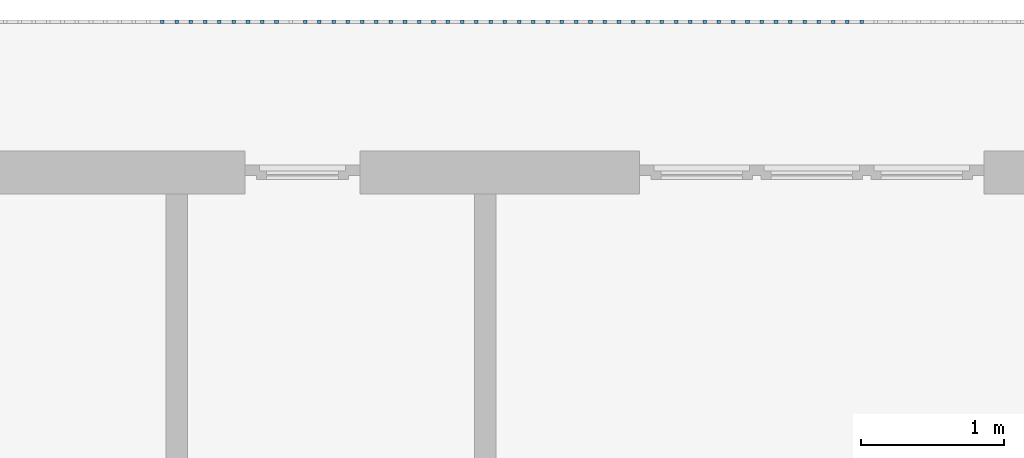
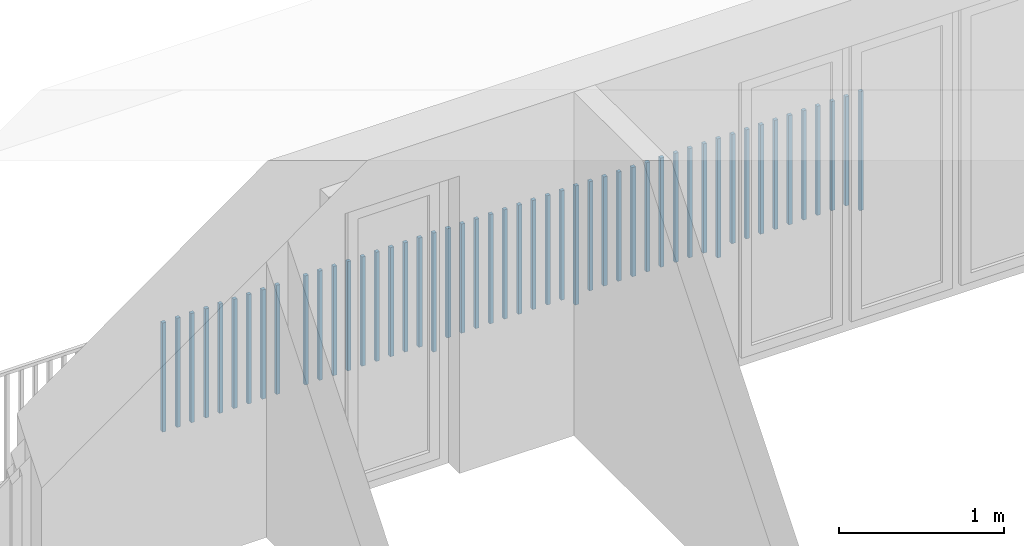
# One storey, part 49 of 54: 49 building element parts, 1 element without a shape of its own.
"""IFC4 building model written with IfcOpenShell, lengths in metres."""

from ifc_helpers import new_model, entity, si_unit, converted_unit, derived_unit, direction, frame, origin_with_axes, place, context, subcontext, project, spatial, polygons, material, type_object, element, aggregate, save


model = new_model("IFC4")

# Units and contexts
model_context = context("Model", 3, precision=1e-05, world=origin_with_axes(), true_north=direction((0.0, 1.0)))
body_context = subcontext(model_context, "Body", "Model", "MODEL_VIEW")
ifc_project = project(units=[si_unit("LENGTHUNIT", "METRE"), si_unit("AREAUNIT", "SQUARE_METRE"), si_unit("VOLUMEUNIT", "CUBIC_METRE"), converted_unit("PLANEANGLEUNIT", "DEGREE", entity("IfcPlaneAngleMeasure", 0.0174532925199), si_unit("PLANEANGLEUNIT", "RADIAN"), dimensions=[0, 0, 0, 0, 0, 0, 0]), converted_unit("TIMEUNIT", "Year", entity("IfcTimeMeasure", 31556926.0), si_unit("TIMEUNIT", "SECOND"), dimensions=[0, 0, 1, 0, 0, 0, 0]), si_unit("MASSUNIT", "GRAM", prefix="KILO"), si_unit("THERMODYNAMICTEMPERATUREUNIT", "DEGREE_CELSIUS"), si_unit("LUMINOUSINTENSITYUNIT", "LUMEN"), si_unit("ENERGYUNIT", "JOULE", prefix="MEGA"), derived_unit("THERMALCONDUCTANCEUNIT", [(si_unit("POWERUNIT", "WATT"), 1), (si_unit("LENGTHUNIT", "METRE"), -1), (si_unit("THERMODYNAMICTEMPERATUREUNIT", "KELVIN"), -1)]), derived_unit("SPECIFICHEATCAPACITYUNIT", [(si_unit("ENERGYUNIT", "JOULE"), 1), (si_unit("MASSUNIT", "GRAM", prefix="KILO"), -1), (si_unit("THERMODYNAMICTEMPERATUREUNIT", "KELVIN"), -1)]), derived_unit("MASSDENSITYUNIT", [(si_unit("MASSUNIT", "GRAM", prefix="KILO"), 1), (si_unit("VOLUMEUNIT", "CUBIC_METRE"), -1)])], contexts=[model_context])

# Site, building, storey, space
site_placement = place(None, origin_with_axes())
site = spatial("IfcSite", under=ifc_project, at=site_placement, CompositionType="ELEMENT")
building_placement = place(site_placement, origin_with_axes())
building = spatial("IfcBuilding", under=site, at=building_placement, CompositionType="ELEMENT")
storey_placement = place(building_placement, frame((0.0, 0.0, 6.29), z_axis=(0.0, 0.0, 1.0), x_axis=(1.0, 0.0, 0.0)))
storey = spatial("IfcBuildingStorey", under=building, at=storey_placement, Name="2. Geschoss", CompositionType="ELEMENT", Elevation=6.29)
space_placement = place(storey_placement, frame((10.2378006196, 9.82118769833, 0.0), z_axis=(0.0, 0.0, 1.0), x_axis=(-1.0, 0.0, 0.0)))
space = spatial("IfcSpace", under=storey, at=space_placement, CompositionType="ELEMENT", PredefinedType="EXTERNAL")

# Railing, building element parts
railing_type = type_object("IfcRailingType", PredefinedType="NOTDEFINED")
railing_placement = place(space_placement, frame((0.0, -7.06315681498e-08, 0.0), z_axis=(0.0, 0.0, 1.0), x_axis=(-1.0, 0.0, 0.0)))
railing = element("IfcRailing", 1, at=railing_placement, inside=space, type_object=railing_type, PredefinedType="NOTDEFINED")
ifc_material = material()
building_element_part_1_placement = place(railing_placement, origin_with_axes())
building_element_part_1 = element("IfcBuildingElementPart", 2, at=building_element_part_1_placement, material=ifc_material, PredefinedType="NOTDEFINED", context=body_context, shape_type="Tessellation", body=[
    polygons([(-12.944673913, 0.0125, 0.0), (-12.944673913, -0.0125, 0.0), (-12.944673913, -0.0125, 0.88), (-12.944673913, 0.0125, 0.88), (-12.919673913, 0.0125, 0.0), (-12.919673913, -0.0125, 0.0), (-12.919673913, -0.0125, 0.88), (-12.919673913, 0.0125, 0.88)], [[[1, 2, 3, 4]], [[1, 5, 6, 2]], [[2, 6, 7, 3]], [[4, 3, 7, 8]], [[5, 1, 4, 8]], [[6, 5, 8, 7]]], closed=True),
])
building_element_part_2_placement = place(railing_placement, origin_with_axes())
building_element_part_2 = element("IfcBuildingElementPart", 3, at=building_element_part_2_placement, material=ifc_material, PredefinedType="NOTDEFINED", context=body_context, shape_type="Tessellation", body=[
    polygons([(-13.0441521739, 0.0125, 0.07), (-13.0441521739, -0.0125, 0.07), (-13.0441521739, -0.0125, 0.8775), (-13.0441521739, 0.0125, 0.8775), (-13.0191521739, 0.0125, 0.07), (-13.0191521739, -0.0125, 0.07), (-13.0191521739, -0.0125, 0.8775), (-13.0191521739, 0.0125, 0.8775)], [[[1, 2, 3, 4]], [[1, 5, 6, 2]], [[2, 6, 7, 3]], [[4, 3, 7, 8]], [[5, 1, 4, 8]], [[6, 5, 8, 7]]], closed=True),
])
building_element_part_3_placement = place(railing_placement, origin_with_axes())
building_element_part_3 = element("IfcBuildingElementPart", 4, at=building_element_part_3_placement, material=ifc_material, PredefinedType="NOTDEFINED", context=body_context, shape_type="Tessellation", body=[
    polygons([(-13.1436304348, 0.0125, 0.07), (-13.1436304348, -0.0125, 0.07), (-13.1436304348, -0.0125, 0.8775), (-13.1436304348, 0.0125, 0.8775), (-13.1186304348, 0.0125, 0.07), (-13.1186304348, -0.0125, 0.07), (-13.1186304348, -0.0125, 0.8775), (-13.1186304348, 0.0125, 0.8775)], [[[1, 2, 3, 4]], [[1, 5, 6, 2]], [[2, 6, 7, 3]], [[4, 3, 7, 8]], [[5, 1, 4, 8]], [[6, 5, 8, 7]]], closed=True),
])
building_element_part_4_placement = place(railing_placement, origin_with_axes())
building_element_part_4 = element("IfcBuildingElementPart", 5, at=building_element_part_4_placement, material=ifc_material, PredefinedType="NOTDEFINED", context=body_context, shape_type="Tessellation", body=[
    polygons([(-13.2431086957, 0.0125, 0.07), (-13.2431086957, -0.0125, 0.07), (-13.2431086957, -0.0125, 0.8775), (-13.2431086957, 0.0125, 0.8775), (-13.2181086957, 0.0125, 0.07), (-13.2181086957, -0.0125, 0.07), (-13.2181086957, -0.0125, 0.8775), (-13.2181086957, 0.0125, 0.8775)], [[[1, 2, 3, 4]], [[1, 5, 6, 2]], [[2, 6, 7, 3]], [[4, 3, 7, 8]], [[5, 1, 4, 8]], [[6, 5, 8, 7]]], closed=True),
])
building_element_part_5_placement = place(railing_placement, origin_with_axes())
building_element_part_5 = element("IfcBuildingElementPart", 6, at=building_element_part_5_placement, material=ifc_material, PredefinedType="NOTDEFINED", context=body_context, shape_type="Tessellation", body=[
    polygons([(-13.3425869565, 0.0125, 0.07), (-13.3425869565, -0.0125, 0.07), (-13.3425869565, -0.0125, 0.8775), (-13.3425869565, 0.0125, 0.8775), (-13.3175869565, 0.0125, 0.07), (-13.3175869565, -0.0125, 0.07), (-13.3175869565, -0.0125, 0.8775), (-13.3175869565, 0.0125, 0.8775)], [[[1, 2, 3, 4]], [[1, 5, 6, 2]], [[2, 6, 7, 3]], [[4, 3, 7, 8]], [[5, 1, 4, 8]], [[6, 5, 8, 7]]], closed=True),
])
building_element_part_6_placement = place(railing_placement, origin_with_axes())
building_element_part_6 = element("IfcBuildingElementPart", 7, at=building_element_part_6_placement, material=ifc_material, PredefinedType="NOTDEFINED", context=body_context, shape_type="Tessellation", body=[
    polygons([(-13.4420652174, 0.0125, 0.07), (-13.4420652174, -0.0125, 0.07), (-13.4420652174, -0.0125, 0.8775), (-13.4420652174, 0.0125, 0.8775), (-13.4170652174, 0.0125, 0.07), (-13.4170652174, -0.0125, 0.07), (-13.4170652174, -0.0125, 0.8775), (-13.4170652174, 0.0125, 0.8775)], [[[1, 2, 3, 4]], [[1, 5, 6, 2]], [[2, 6, 7, 3]], [[4, 3, 7, 8]], [[5, 1, 4, 8]], [[6, 5, 8, 7]]], closed=True),
])
building_element_part_7_placement = place(railing_placement, origin_with_axes())
building_element_part_7 = element("IfcBuildingElementPart", 8, at=building_element_part_7_placement, material=ifc_material, PredefinedType="NOTDEFINED", context=body_context, shape_type="Tessellation", body=[
    polygons([(-13.5415434783, 0.0125, 0.07), (-13.5415434783, -0.0125, 0.07), (-13.5415434783, -0.0125, 0.8775), (-13.5415434783, 0.0125, 0.8775), (-13.5165434783, 0.0125, 0.07), (-13.5165434783, -0.0125, 0.07), (-13.5165434783, -0.0125, 0.8775), (-13.5165434783, 0.0125, 0.8775)], [[[1, 2, 3, 4]], [[1, 5, 6, 2]], [[2, 6, 7, 3]], [[4, 3, 7, 8]], [[5, 1, 4, 8]], [[6, 5, 8, 7]]], closed=True),
])
building_element_part_8_placement = place(railing_placement, origin_with_axes())
building_element_part_8 = element("IfcBuildingElementPart", 9, at=building_element_part_8_placement, material=ifc_material, PredefinedType="NOTDEFINED", context=body_context, shape_type="Tessellation", body=[
    polygons([(-13.6410217391, 0.0125, 0.07), (-13.6410217391, -0.0125, 0.07), (-13.6410217391, -0.0125, 0.8775), (-13.6410217391, 0.0125, 0.8775), (-13.6160217391, 0.0125, 0.07), (-13.6160217391, -0.0125, 0.07), (-13.6160217391, -0.0125, 0.8775), (-13.6160217391, 0.0125, 0.8775)], [[[1, 2, 3, 4]], [[1, 5, 6, 2]], [[2, 6, 7, 3]], [[4, 3, 7, 8]], [[5, 1, 4, 8]], [[6, 5, 8, 7]]], closed=True),
])
building_element_part_9_placement = place(railing_placement, origin_with_axes())
building_element_part_9 = element("IfcBuildingElementPart", 10, at=building_element_part_9_placement, material=ifc_material, PredefinedType="NOTDEFINED", context=body_context, shape_type="Tessellation", body=[
    polygons([(-13.7405, 0.0125, 0.07), (-13.7405, -0.0125, 0.07), (-13.7405, -0.0125, 0.8775), (-13.7405, 0.0125, 0.8775), (-13.7155, 0.0125, 0.07), (-13.7155, -0.0125, 0.07), (-13.7155, -0.0125, 0.8775), (-13.7155, 0.0125, 0.8775)], [[[1, 2, 3, 4]], [[1, 5, 6, 2]], [[2, 6, 7, 3]], [[4, 3, 7, 8]], [[5, 1, 4, 8]], [[6, 5, 8, 7]]], closed=True),
])
building_element_part_10_placement = place(railing_placement, origin_with_axes())
building_element_part_10 = element("IfcBuildingElementPart", 11, at=building_element_part_10_placement, material=ifc_material, PredefinedType="NOTDEFINED", context=body_context, shape_type="Tessellation", body=[
    polygons([(-13.8399782609, 0.0125, 0.07), (-13.8399782609, -0.0125, 0.07), (-13.8399782609, -0.0125, 0.8775), (-13.8399782609, 0.0125, 0.8775), (-13.8149782609, 0.0125, 0.07), (-13.8149782609, -0.0125, 0.07), (-13.8149782609, -0.0125, 0.8775), (-13.8149782609, 0.0125, 0.8775)], [[[1, 2, 3, 4]], [[1, 5, 6, 2]], [[2, 6, 7, 3]], [[4, 3, 7, 8]], [[5, 1, 4, 8]], [[6, 5, 8, 7]]], closed=True),
])
building_element_part_11_placement = place(railing_placement, origin_with_axes())
building_element_part_11 = element("IfcBuildingElementPart", 12, at=building_element_part_11_placement, material=ifc_material, PredefinedType="NOTDEFINED", context=body_context, shape_type="Tessellation", body=[
    polygons([(-13.9394565217, 0.0125, 0.0), (-13.9394565217, -0.0125, 0.0), (-13.9394565217, -0.0125, 0.88), (-13.9394565217, 0.0125, 0.88), (-13.9144565217, 0.0125, 0.0), (-13.9144565217, -0.0125, 0.0), (-13.9144565217, -0.0125, 0.88), (-13.9144565217, 0.0125, 0.88)], [[[1, 2, 3, 4]], [[1, 5, 6, 2]], [[2, 6, 7, 3]], [[4, 3, 7, 8]], [[5, 1, 4, 8]], [[6, 5, 8, 7]]], closed=True),
])
building_element_part_12_placement = place(railing_placement, origin_with_axes())
building_element_part_12 = element("IfcBuildingElementPart", 13, at=building_element_part_12_placement, material=ifc_material, PredefinedType="NOTDEFINED", context=body_context, shape_type="Tessellation", body=[
    polygons([(-14.0389347826, 0.0125, 0.07), (-14.0389347826, -0.0125, 0.07), (-14.0389347826, -0.0125, 0.8775), (-14.0389347826, 0.0125, 0.8775), (-14.0139347826, 0.0125, 0.07), (-14.0139347826, -0.0125, 0.07), (-14.0139347826, -0.0125, 0.8775), (-14.0139347826, 0.0125, 0.8775)], [[[1, 2, 3, 4]], [[1, 5, 6, 2]], [[2, 6, 7, 3]], [[4, 3, 7, 8]], [[5, 1, 4, 8]], [[6, 5, 8, 7]]], closed=True),
])
building_element_part_13_placement = place(railing_placement, origin_with_axes())
building_element_part_13 = element("IfcBuildingElementPart", 14, at=building_element_part_13_placement, material=ifc_material, PredefinedType="NOTDEFINED", context=body_context, shape_type="Tessellation", body=[
    polygons([(-14.1384130435, 0.0125, 0.07), (-14.1384130435, -0.0125, 0.07), (-14.1384130435, -0.0125, 0.8775), (-14.1384130435, 0.0125, 0.8775), (-14.1134130435, 0.0125, 0.07), (-14.1134130435, -0.0125, 0.07), (-14.1134130435, -0.0125, 0.8775), (-14.1134130435, 0.0125, 0.8775)], [[[1, 2, 3, 4]], [[1, 5, 6, 2]], [[2, 6, 7, 3]], [[4, 3, 7, 8]], [[5, 1, 4, 8]], [[6, 5, 8, 7]]], closed=True),
])
building_element_part_14_placement = place(railing_placement, origin_with_axes())
building_element_part_14 = element("IfcBuildingElementPart", 15, at=building_element_part_14_placement, material=ifc_material, PredefinedType="NOTDEFINED", context=body_context, shape_type="Tessellation", body=[
    polygons([(-14.2378913043, 0.0125, 0.07), (-14.2378913043, -0.0125, 0.07), (-14.2378913043, -0.0125, 0.8775), (-14.2378913043, 0.0125, 0.8775), (-14.2128913043, 0.0125, 0.07), (-14.2128913043, -0.0125, 0.07), (-14.2128913043, -0.0125, 0.8775), (-14.2128913043, 0.0125, 0.8775)], [[[1, 2, 3, 4]], [[1, 5, 6, 2]], [[2, 6, 7, 3]], [[4, 3, 7, 8]], [[5, 1, 4, 8]], [[6, 5, 8, 7]]], closed=True),
])
building_element_part_15_placement = place(railing_placement, origin_with_axes())
building_element_part_15 = element("IfcBuildingElementPart", 16, at=building_element_part_15_placement, material=ifc_material, PredefinedType="NOTDEFINED", context=body_context, shape_type="Tessellation", body=[
    polygons([(-14.3373695652, 0.0125, 0.07), (-14.3373695652, -0.0125, 0.07), (-14.3373695652, -0.0125, 0.8775), (-14.3373695652, 0.0125, 0.8775), (-14.3123695652, 0.0125, 0.07), (-14.3123695652, -0.0125, 0.07), (-14.3123695652, -0.0125, 0.8775), (-14.3123695652, 0.0125, 0.8775)], [[[1, 2, 3, 4]], [[1, 5, 6, 2]], [[2, 6, 7, 3]], [[4, 3, 7, 8]], [[5, 1, 4, 8]], [[6, 5, 8, 7]]], closed=True),
])
building_element_part_16_placement = place(railing_placement, origin_with_axes())
building_element_part_16 = element("IfcBuildingElementPart", 17, at=building_element_part_16_placement, material=ifc_material, PredefinedType="NOTDEFINED", context=body_context, shape_type="Tessellation", body=[
    polygons([(-14.4368478261, 0.0125, 0.07), (-14.4368478261, -0.0125, 0.07), (-14.4368478261, -0.0125, 0.8775), (-14.4368478261, 0.0125, 0.8775), (-14.4118478261, 0.0125, 0.07), (-14.4118478261, -0.0125, 0.07), (-14.4118478261, -0.0125, 0.8775), (-14.4118478261, 0.0125, 0.8775)], [[[1, 2, 3, 4]], [[1, 5, 6, 2]], [[2, 6, 7, 3]], [[4, 3, 7, 8]], [[5, 1, 4, 8]], [[6, 5, 8, 7]]], closed=True),
])
building_element_part_17_placement = place(railing_placement, origin_with_axes())
building_element_part_17 = element("IfcBuildingElementPart", 18, at=building_element_part_17_placement, material=ifc_material, PredefinedType="NOTDEFINED", context=body_context, shape_type="Tessellation", body=[
    polygons([(-14.536326087, 0.0125, 0.07), (-14.536326087, -0.0125, 0.07), (-14.536326087, -0.0125, 0.8775), (-14.536326087, 0.0125, 0.8775), (-14.511326087, 0.0125, 0.07), (-14.511326087, -0.0125, 0.07), (-14.511326087, -0.0125, 0.8775), (-14.511326087, 0.0125, 0.8775)], [[[1, 2, 3, 4]], [[1, 5, 6, 2]], [[2, 6, 7, 3]], [[4, 3, 7, 8]], [[5, 1, 4, 8]], [[6, 5, 8, 7]]], closed=True),
])
building_element_part_18_placement = place(railing_placement, origin_with_axes())
building_element_part_18 = element("IfcBuildingElementPart", 19, at=building_element_part_18_placement, material=ifc_material, PredefinedType="NOTDEFINED", context=body_context, shape_type="Tessellation", body=[
    polygons([(-14.6358043478, 0.0125, 0.07), (-14.6358043478, -0.0125, 0.07), (-14.6358043478, -0.0125, 0.8775), (-14.6358043478, 0.0125, 0.8775), (-14.6108043478, 0.0125, 0.07), (-14.6108043478, -0.0125, 0.07), (-14.6108043478, -0.0125, 0.8775), (-14.6108043478, 0.0125, 0.8775)], [[[1, 2, 3, 4]], [[1, 5, 6, 2]], [[2, 6, 7, 3]], [[4, 3, 7, 8]], [[5, 1, 4, 8]], [[6, 5, 8, 7]]], closed=True),
])
building_element_part_19_placement = place(railing_placement, origin_with_axes())
building_element_part_19 = element("IfcBuildingElementPart", 20, at=building_element_part_19_placement, material=ifc_material, PredefinedType="NOTDEFINED", context=body_context, shape_type="Tessellation", body=[
    polygons([(-14.7352826087, 0.0125, 0.07), (-14.7352826087, -0.0125, 0.07), (-14.7352826087, -0.0125, 0.8775), (-14.7352826087, 0.0125, 0.8775), (-14.7102826087, 0.0125, 0.07), (-14.7102826087, -0.0125, 0.07), (-14.7102826087, -0.0125, 0.8775), (-14.7102826087, 0.0125, 0.8775)], [[[1, 2, 3, 4]], [[1, 5, 6, 2]], [[2, 6, 7, 3]], [[4, 3, 7, 8]], [[5, 1, 4, 8]], [[6, 5, 8, 7]]], closed=True),
])
building_element_part_20_placement = place(railing_placement, origin_with_axes())
building_element_part_20 = element("IfcBuildingElementPart", 21, at=building_element_part_20_placement, material=ifc_material, PredefinedType="NOTDEFINED", context=body_context, shape_type="Tessellation", body=[
    polygons([(-14.8347608696, 0.0125, 0.07), (-14.8347608696, -0.0125, 0.07), (-14.8347608696, -0.0125, 0.8775), (-14.8347608696, 0.0125, 0.8775), (-14.8097608696, 0.0125, 0.07), (-14.8097608696, -0.0125, 0.07), (-14.8097608696, -0.0125, 0.8775), (-14.8097608696, 0.0125, 0.8775)], [[[1, 2, 3, 4]], [[1, 5, 6, 2]], [[2, 6, 7, 3]], [[4, 3, 7, 8]], [[5, 1, 4, 8]], [[6, 5, 8, 7]]], closed=True),
])
building_element_part_21_placement = place(railing_placement, origin_with_axes())
building_element_part_21 = element("IfcBuildingElementPart", 22, at=building_element_part_21_placement, material=ifc_material, PredefinedType="NOTDEFINED", context=body_context, shape_type="Tessellation", body=[
    polygons([(-14.9342391304, 0.0125, 0.0), (-14.9342391304, -0.0125, 0.0), (-14.9342391304, -0.0125, 0.88), (-14.9342391304, 0.0125, 0.88), (-14.9092391304, 0.0125, 0.0), (-14.9092391304, -0.0125, 0.0), (-14.9092391304, -0.0125, 0.88), (-14.9092391304, 0.0125, 0.88)], [[[1, 2, 3, 4]], [[1, 5, 6, 2]], [[2, 6, 7, 3]], [[4, 3, 7, 8]], [[5, 1, 4, 8]], [[6, 5, 8, 7]]], closed=True),
])
building_element_part_22_placement = place(railing_placement, origin_with_axes())
building_element_part_22 = element("IfcBuildingElementPart", 23, at=building_element_part_22_placement, material=ifc_material, PredefinedType="NOTDEFINED", context=body_context, shape_type="Tessellation", body=[
    polygons([(-15.0337173913, 0.0125, 0.07), (-15.0337173913, -0.0125, 0.07), (-15.0337173913, -0.0125, 0.8775), (-15.0337173913, 0.0125, 0.8775), (-15.0087173913, 0.0125, 0.07), (-15.0087173913, -0.0125, 0.07), (-15.0087173913, -0.0125, 0.8775), (-15.0087173913, 0.0125, 0.8775)], [[[1, 2, 3, 4]], [[1, 5, 6, 2]], [[2, 6, 7, 3]], [[4, 3, 7, 8]], [[5, 1, 4, 8]], [[6, 5, 8, 7]]], closed=True),
])
building_element_part_23_placement = place(railing_placement, origin_with_axes())
building_element_part_23 = element("IfcBuildingElementPart", 24, at=building_element_part_23_placement, material=ifc_material, PredefinedType="NOTDEFINED", context=body_context, shape_type="Tessellation", body=[
    polygons([(-15.1331956522, 0.0125, 0.07), (-15.1331956522, -0.0125, 0.07), (-15.1331956522, -0.0125, 0.8775), (-15.1331956522, 0.0125, 0.8775), (-15.1081956522, 0.0125, 0.07), (-15.1081956522, -0.0125, 0.07), (-15.1081956522, -0.0125, 0.8775), (-15.1081956522, 0.0125, 0.8775)], [[[1, 2, 3, 4]], [[1, 5, 6, 2]], [[2, 6, 7, 3]], [[4, 3, 7, 8]], [[5, 1, 4, 8]], [[6, 5, 8, 7]]], closed=True),
])
building_element_part_24_placement = place(railing_placement, origin_with_axes())
building_element_part_24 = element("IfcBuildingElementPart", 25, at=building_element_part_24_placement, material=ifc_material, PredefinedType="NOTDEFINED", context=body_context, shape_type="Tessellation", body=[
    polygons([(-15.232673913, 0.0125, 0.07), (-15.232673913, -0.0125, 0.07), (-15.232673913, -0.0125, 0.8775), (-15.232673913, 0.0125, 0.8775), (-15.207673913, 0.0125, 0.07), (-15.207673913, -0.0125, 0.07), (-15.207673913, -0.0125, 0.8775), (-15.207673913, 0.0125, 0.8775)], [[[1, 2, 3, 4]], [[1, 5, 6, 2]], [[2, 6, 7, 3]], [[4, 3, 7, 8]], [[5, 1, 4, 8]], [[6, 5, 8, 7]]], closed=True),
])
building_element_part_25_placement = place(railing_placement, origin_with_axes())
building_element_part_25 = element("IfcBuildingElementPart", 26, at=building_element_part_25_placement, material=ifc_material, PredefinedType="NOTDEFINED", context=body_context, shape_type="Tessellation", body=[
    polygons([(-15.3321521739, 0.0125, 0.07), (-15.3321521739, -0.0125, 0.07), (-15.3321521739, -0.0125, 0.8775), (-15.3321521739, 0.0125, 0.8775), (-15.3071521739, 0.0125, 0.07), (-15.3071521739, -0.0125, 0.07), (-15.3071521739, -0.0125, 0.8775), (-15.3071521739, 0.0125, 0.8775)], [[[1, 2, 3, 4]], [[1, 5, 6, 2]], [[2, 6, 7, 3]], [[4, 3, 7, 8]], [[5, 1, 4, 8]], [[6, 5, 8, 7]]], closed=True),
])
building_element_part_26_placement = place(railing_placement, origin_with_axes())
building_element_part_26 = element("IfcBuildingElementPart", 27, at=building_element_part_26_placement, material=ifc_material, PredefinedType="NOTDEFINED", context=body_context, shape_type="Tessellation", body=[
    polygons([(-15.4316304348, 0.0125, 0.07), (-15.4316304348, -0.0125, 0.07), (-15.4316304348, -0.0125, 0.8775), (-15.4316304348, 0.0125, 0.8775), (-15.4066304348, 0.0125, 0.07), (-15.4066304348, -0.0125, 0.07), (-15.4066304348, -0.0125, 0.8775), (-15.4066304348, 0.0125, 0.8775)], [[[1, 2, 3, 4]], [[1, 5, 6, 2]], [[2, 6, 7, 3]], [[4, 3, 7, 8]], [[5, 1, 4, 8]], [[6, 5, 8, 7]]], closed=True),
])
building_element_part_27_placement = place(railing_placement, origin_with_axes())
building_element_part_27 = element("IfcBuildingElementPart", 28, at=building_element_part_27_placement, material=ifc_material, PredefinedType="NOTDEFINED", context=body_context, shape_type="Tessellation", body=[
    polygons([(-15.5311086957, 0.0125, 0.07), (-15.5311086957, -0.0125, 0.07), (-15.5311086957, -0.0125, 0.8775), (-15.5311086957, 0.0125, 0.8775), (-15.5061086957, 0.0125, 0.07), (-15.5061086957, -0.0125, 0.07), (-15.5061086957, -0.0125, 0.8775), (-15.5061086957, 0.0125, 0.8775)], [[[1, 2, 3, 4]], [[1, 5, 6, 2]], [[2, 6, 7, 3]], [[4, 3, 7, 8]], [[5, 1, 4, 8]], [[6, 5, 8, 7]]], closed=True),
])
building_element_part_28_placement = place(railing_placement, origin_with_axes())
building_element_part_28 = element("IfcBuildingElementPart", 29, at=building_element_part_28_placement, material=ifc_material, PredefinedType="NOTDEFINED", context=body_context, shape_type="Tessellation", body=[
    polygons([(-15.6305869565, 0.0125, 0.07), (-15.6305869565, -0.0125, 0.07), (-15.6305869565, -0.0125, 0.8775), (-15.6305869565, 0.0125, 0.8775), (-15.6055869565, 0.0125, 0.07), (-15.6055869565, -0.0125, 0.07), (-15.6055869565, -0.0125, 0.8775), (-15.6055869565, 0.0125, 0.8775)], [[[1, 2, 3, 4]], [[1, 5, 6, 2]], [[2, 6, 7, 3]], [[4, 3, 7, 8]], [[5, 1, 4, 8]], [[6, 5, 8, 7]]], closed=True),
])
building_element_part_29_placement = place(railing_placement, origin_with_axes())
building_element_part_29 = element("IfcBuildingElementPart", 30, at=building_element_part_29_placement, material=ifc_material, PredefinedType="NOTDEFINED", context=body_context, shape_type="Tessellation", body=[
    polygons([(-15.7300652174, 0.0125, 0.07), (-15.7300652174, -0.0125, 0.07), (-15.7300652174, -0.0125, 0.8775), (-15.7300652174, 0.0125, 0.8775), (-15.7050652174, 0.0125, 0.07), (-15.7050652174, -0.0125, 0.07), (-15.7050652174, -0.0125, 0.8775), (-15.7050652174, 0.0125, 0.8775)], [[[1, 2, 3, 4]], [[1, 5, 6, 2]], [[2, 6, 7, 3]], [[4, 3, 7, 8]], [[5, 1, 4, 8]], [[6, 5, 8, 7]]], closed=True),
])
building_element_part_30_placement = place(railing_placement, origin_with_axes())
building_element_part_30 = element("IfcBuildingElementPart", 31, at=building_element_part_30_placement, material=ifc_material, PredefinedType="NOTDEFINED", context=body_context, shape_type="Tessellation", body=[
    polygons([(-15.8295434783, 0.0125, 0.07), (-15.8295434783, -0.0125, 0.07), (-15.8295434783, -0.0125, 0.8775), (-15.8295434783, 0.0125, 0.8775), (-15.8045434783, 0.0125, 0.07), (-15.8045434783, -0.0125, 0.07), (-15.8045434783, -0.0125, 0.8775), (-15.8045434783, 0.0125, 0.8775)], [[[1, 2, 3, 4]], [[1, 5, 6, 2]], [[2, 6, 7, 3]], [[4, 3, 7, 8]], [[5, 1, 4, 8]], [[6, 5, 8, 7]]], closed=True),
])
building_element_part_31_placement = place(railing_placement, origin_with_axes())
building_element_part_31 = element("IfcBuildingElementPart", 32, at=building_element_part_31_placement, material=ifc_material, PredefinedType="NOTDEFINED", context=body_context, shape_type="Tessellation", body=[
    polygons([(-15.9290217391, 0.0125, 0.0), (-15.9290217391, -0.0125, 0.0), (-15.9290217391, -0.0125, 0.88), (-15.9290217391, 0.0125, 0.88), (-15.9040217391, 0.0125, 0.0), (-15.9040217391, -0.0125, 0.0), (-15.9040217391, -0.0125, 0.88), (-15.9040217391, 0.0125, 0.88)], [[[1, 2, 3, 4]], [[1, 5, 6, 2]], [[2, 6, 7, 3]], [[4, 3, 7, 8]], [[5, 1, 4, 8]], [[6, 5, 8, 7]]], closed=True),
])
building_element_part_32_placement = place(railing_placement, origin_with_axes())
building_element_part_32 = element("IfcBuildingElementPart", 33, at=building_element_part_32_placement, material=ifc_material, PredefinedType="NOTDEFINED", context=body_context, shape_type="Tessellation", body=[
    polygons([(-16.0285, 0.0125, 0.07), (-16.0285, -0.0125, 0.07), (-16.0285, -0.0125, 0.8775), (-16.0285, 0.0125, 0.8775), (-16.0035, 0.0125, 0.07), (-16.0035, -0.0125, 0.07), (-16.0035, -0.0125, 0.8775), (-16.0035, 0.0125, 0.8775)], [[[1, 2, 3, 4]], [[1, 5, 6, 2]], [[2, 6, 7, 3]], [[4, 3, 7, 8]], [[5, 1, 4, 8]], [[6, 5, 8, 7]]], closed=True),
])
building_element_part_33_placement = place(railing_placement, origin_with_axes())
building_element_part_33 = element("IfcBuildingElementPart", 34, at=building_element_part_33_placement, material=ifc_material, PredefinedType="NOTDEFINED", context=body_context, shape_type="Tessellation", body=[
    polygons([(-16.1279782609, 0.0125, 0.07), (-16.1279782609, -0.0125, 0.07), (-16.1279782609, -0.0125, 0.8775), (-16.1279782609, 0.0125, 0.8775), (-16.1029782609, 0.0125, 0.07), (-16.1029782609, -0.0125, 0.07), (-16.1029782609, -0.0125, 0.8775), (-16.1029782609, 0.0125, 0.8775)], [[[1, 2, 3, 4]], [[1, 5, 6, 2]], [[2, 6, 7, 3]], [[4, 3, 7, 8]], [[5, 1, 4, 8]], [[6, 5, 8, 7]]], closed=True),
])
building_element_part_34_placement = place(railing_placement, origin_with_axes())
building_element_part_34 = element("IfcBuildingElementPart", 35, at=building_element_part_34_placement, material=ifc_material, PredefinedType="NOTDEFINED", context=body_context, shape_type="Tessellation", body=[
    polygons([(-16.2274565217, 0.0125, 0.07), (-16.2274565217, -0.0125, 0.07), (-16.2274565217, -0.0125, 0.8775), (-16.2274565217, 0.0125, 0.8775), (-16.2024565217, 0.0125, 0.07), (-16.2024565217, -0.0125, 0.07), (-16.2024565217, -0.0125, 0.8775), (-16.2024565217, 0.0125, 0.8775)], [[[1, 2, 3, 4]], [[1, 5, 6, 2]], [[2, 6, 7, 3]], [[4, 3, 7, 8]], [[5, 1, 4, 8]], [[6, 5, 8, 7]]], closed=True),
])
building_element_part_35_placement = place(railing_placement, origin_with_axes())
building_element_part_35 = element("IfcBuildingElementPart", 36, at=building_element_part_35_placement, material=ifc_material, PredefinedType="NOTDEFINED", context=body_context, shape_type="Tessellation", body=[
    polygons([(-16.3269347826, 0.0125, 0.07), (-16.3269347826, -0.0125, 0.07), (-16.3269347826, -0.0125, 0.8775), (-16.3269347826, 0.0125, 0.8775), (-16.3019347826, 0.0125, 0.07), (-16.3019347826, -0.0125, 0.07), (-16.3019347826, -0.0125, 0.8775), (-16.3019347826, 0.0125, 0.8775)], [[[1, 2, 3, 4]], [[1, 5, 6, 2]], [[2, 6, 7, 3]], [[4, 3, 7, 8]], [[5, 1, 4, 8]], [[6, 5, 8, 7]]], closed=True),
])
building_element_part_36_placement = place(railing_placement, origin_with_axes())
building_element_part_36 = element("IfcBuildingElementPart", 37, at=building_element_part_36_placement, material=ifc_material, PredefinedType="NOTDEFINED", context=body_context, shape_type="Tessellation", body=[
    polygons([(-16.4264130435, 0.0125, 0.07), (-16.4264130435, -0.0125, 0.07), (-16.4264130435, -0.0125, 0.8775), (-16.4264130435, 0.0125, 0.8775), (-16.4014130435, 0.0125, 0.07), (-16.4014130435, -0.0125, 0.07), (-16.4014130435, -0.0125, 0.8775), (-16.4014130435, 0.0125, 0.8775)], [[[1, 2, 3, 4]], [[1, 5, 6, 2]], [[2, 6, 7, 3]], [[4, 3, 7, 8]], [[5, 1, 4, 8]], [[6, 5, 8, 7]]], closed=True),
])
building_element_part_37_placement = place(railing_placement, origin_with_axes())
building_element_part_37 = element("IfcBuildingElementPart", 38, at=building_element_part_37_placement, material=ifc_material, PredefinedType="NOTDEFINED", context=body_context, shape_type="Tessellation", body=[
    polygons([(-16.5258913043, 0.0125, 0.07), (-16.5258913043, -0.0125, 0.07), (-16.5258913043, -0.0125, 0.8775), (-16.5258913043, 0.0125, 0.8775), (-16.5008913043, 0.0125, 0.07), (-16.5008913043, -0.0125, 0.07), (-16.5008913043, -0.0125, 0.8775), (-16.5008913043, 0.0125, 0.8775)], [[[1, 2, 3, 4]], [[1, 5, 6, 2]], [[2, 6, 7, 3]], [[4, 3, 7, 8]], [[5, 1, 4, 8]], [[6, 5, 8, 7]]], closed=True),
])
building_element_part_38_placement = place(railing_placement, origin_with_axes())
building_element_part_38 = element("IfcBuildingElementPart", 39, at=building_element_part_38_placement, material=ifc_material, PredefinedType="NOTDEFINED", context=body_context, shape_type="Tessellation", body=[
    polygons([(-16.6253695652, 0.0125, 0.07), (-16.6253695652, -0.0125, 0.07), (-16.6253695652, -0.0125, 0.8775), (-16.6253695652, 0.0125, 0.8775), (-16.6003695652, 0.0125, 0.07), (-16.6003695652, -0.0125, 0.07), (-16.6003695652, -0.0125, 0.8775), (-16.6003695652, 0.0125, 0.8775)], [[[1, 2, 3, 4]], [[1, 5, 6, 2]], [[2, 6, 7, 3]], [[4, 3, 7, 8]], [[5, 1, 4, 8]], [[6, 5, 8, 7]]], closed=True),
])
building_element_part_39_placement = place(railing_placement, origin_with_axes())
building_element_part_39 = element("IfcBuildingElementPart", 40, at=building_element_part_39_placement, material=ifc_material, PredefinedType="NOTDEFINED", context=body_context, shape_type="Tessellation", body=[
    polygons([(-16.7248478261, 0.0125, 0.07), (-16.7248478261, -0.0125, 0.07), (-16.7248478261, -0.0125, 0.8775), (-16.7248478261, 0.0125, 0.8775), (-16.6998478261, 0.0125, 0.07), (-16.6998478261, -0.0125, 0.07), (-16.6998478261, -0.0125, 0.8775), (-16.6998478261, 0.0125, 0.8775)], [[[1, 2, 3, 4]], [[1, 5, 6, 2]], [[2, 6, 7, 3]], [[4, 3, 7, 8]], [[5, 1, 4, 8]], [[6, 5, 8, 7]]], closed=True),
])
building_element_part_40_placement = place(railing_placement, origin_with_axes())
building_element_part_40 = element("IfcBuildingElementPart", 41, at=building_element_part_40_placement, material=ifc_material, PredefinedType="NOTDEFINED", context=body_context, shape_type="Tessellation", body=[
    polygons([(-16.824326087, 0.0125, 0.07), (-16.824326087, -0.0125, 0.07), (-16.824326087, -0.0125, 0.8775), (-16.824326087, 0.0125, 0.8775), (-16.799326087, 0.0125, 0.07), (-16.799326087, -0.0125, 0.07), (-16.799326087, -0.0125, 0.8775), (-16.799326087, 0.0125, 0.8775)], [[[1, 2, 3, 4]], [[1, 5, 6, 2]], [[2, 6, 7, 3]], [[4, 3, 7, 8]], [[5, 1, 4, 8]], [[6, 5, 8, 7]]], closed=True),
])
building_element_part_41_placement = place(railing_placement, origin_with_axes())
building_element_part_41 = element("IfcBuildingElementPart", 42, at=building_element_part_41_placement, material=ifc_material, PredefinedType="NOTDEFINED", context=body_context, shape_type="Tessellation", body=[
    polygons([(-17.0232826087, 0.0125, 0.07), (-17.0232826087, -0.0125, 0.07), (-17.0232826087, -0.0125, 0.8775), (-17.0232826087, 0.0125, 0.8775), (-16.9982826087, 0.0125, 0.07), (-16.9982826087, -0.0125, 0.07), (-16.9982826087, -0.0125, 0.8775), (-16.9982826087, 0.0125, 0.8775)], [[[1, 2, 3, 4]], [[1, 5, 6, 2]], [[2, 6, 7, 3]], [[4, 3, 7, 8]], [[5, 1, 4, 8]], [[6, 5, 8, 7]]], closed=True),
])
building_element_part_42_placement = place(railing_placement, origin_with_axes())
building_element_part_42 = element("IfcBuildingElementPart", 43, at=building_element_part_42_placement, material=ifc_material, PredefinedType="NOTDEFINED", context=body_context, shape_type="Tessellation", body=[
    polygons([(-17.1227608696, 0.0125, 0.07), (-17.1227608696, -0.0125, 0.07), (-17.1227608696, -0.0125, 0.8775), (-17.1227608696, 0.0125, 0.8775), (-17.0977608696, 0.0125, 0.07), (-17.0977608696, -0.0125, 0.07), (-17.0977608696, -0.0125, 0.8775), (-17.0977608696, 0.0125, 0.8775)], [[[1, 2, 3, 4]], [[1, 5, 6, 2]], [[2, 6, 7, 3]], [[4, 3, 7, 8]], [[5, 1, 4, 8]], [[6, 5, 8, 7]]], closed=True),
])
building_element_part_43_placement = place(railing_placement, origin_with_axes())
building_element_part_43 = element("IfcBuildingElementPart", 44, at=building_element_part_43_placement, material=ifc_material, PredefinedType="NOTDEFINED", context=body_context, shape_type="Tessellation", body=[
    polygons([(-17.2222391304, 0.0125, 0.07), (-17.2222391304, -0.0125, 0.07), (-17.2222391304, -0.0125, 0.8775), (-17.2222391304, 0.0125, 0.8775), (-17.1972391304, 0.0125, 0.07), (-17.1972391304, -0.0125, 0.07), (-17.1972391304, -0.0125, 0.8775), (-17.1972391304, 0.0125, 0.8775)], [[[1, 2, 3, 4]], [[1, 5, 6, 2]], [[2, 6, 7, 3]], [[4, 3, 7, 8]], [[5, 1, 4, 8]], [[6, 5, 8, 7]]], closed=True),
])
building_element_part_44_placement = place(railing_placement, origin_with_axes())
building_element_part_44 = element("IfcBuildingElementPart", 45, at=building_element_part_44_placement, material=ifc_material, PredefinedType="NOTDEFINED", context=body_context, shape_type="Tessellation", body=[
    polygons([(-17.3217173913, 0.0125, 0.07), (-17.3217173913, -0.0125, 0.07), (-17.3217173913, -0.0125, 0.8775), (-17.3217173913, 0.0125, 0.8775), (-17.2967173913, 0.0125, 0.07), (-17.2967173913, -0.0125, 0.07), (-17.2967173913, -0.0125, 0.8775), (-17.2967173913, 0.0125, 0.8775)], [[[1, 2, 3, 4]], [[1, 5, 6, 2]], [[2, 6, 7, 3]], [[4, 3, 7, 8]], [[5, 1, 4, 8]], [[6, 5, 8, 7]]], closed=True),
])
building_element_part_45_placement = place(railing_placement, origin_with_axes())
building_element_part_45 = element("IfcBuildingElementPart", 46, at=building_element_part_45_placement, material=ifc_material, PredefinedType="NOTDEFINED", context=body_context, shape_type="Tessellation", body=[
    polygons([(-17.4211956522, 0.0125, 0.07), (-17.4211956522, -0.0125, 0.07), (-17.4211956522, -0.0125, 0.8775), (-17.4211956522, 0.0125, 0.8775), (-17.3961956522, 0.0125, 0.07), (-17.3961956522, -0.0125, 0.07), (-17.3961956522, -0.0125, 0.8775), (-17.3961956522, 0.0125, 0.8775)], [[[1, 2, 3, 4]], [[1, 5, 6, 2]], [[2, 6, 7, 3]], [[4, 3, 7, 8]], [[5, 1, 4, 8]], [[6, 5, 8, 7]]], closed=True),
])
building_element_part_46_placement = place(railing_placement, origin_with_axes())
building_element_part_46 = element("IfcBuildingElementPart", 47, at=building_element_part_46_placement, material=ifc_material, PredefinedType="NOTDEFINED", context=body_context, shape_type="Tessellation", body=[
    polygons([(-17.520673913, 0.0125, 0.07), (-17.520673913, -0.0125, 0.07), (-17.520673913, -0.0125, 0.8775), (-17.520673913, 0.0125, 0.8775), (-17.495673913, 0.0125, 0.07), (-17.495673913, -0.0125, 0.07), (-17.495673913, -0.0125, 0.8775), (-17.495673913, 0.0125, 0.8775)], [[[1, 2, 3, 4]], [[1, 5, 6, 2]], [[2, 6, 7, 3]], [[4, 3, 7, 8]], [[5, 1, 4, 8]], [[6, 5, 8, 7]]], closed=True),
])
building_element_part_47_placement = place(railing_placement, origin_with_axes())
building_element_part_47 = element("IfcBuildingElementPart", 48, at=building_element_part_47_placement, material=ifc_material, PredefinedType="NOTDEFINED", context=body_context, shape_type="Tessellation", body=[
    polygons([(-17.6201521739, 0.0125, 0.07), (-17.6201521739, -0.0125, 0.07), (-17.6201521739, -0.0125, 0.8775), (-17.6201521739, 0.0125, 0.8775), (-17.5951521739, 0.0125, 0.07), (-17.5951521739, -0.0125, 0.07), (-17.5951521739, -0.0125, 0.8775), (-17.5951521739, 0.0125, 0.8775)], [[[1, 2, 3, 4]], [[1, 5, 6, 2]], [[2, 6, 7, 3]], [[4, 3, 7, 8]], [[5, 1, 4, 8]], [[6, 5, 8, 7]]], closed=True),
])
building_element_part_48_placement = place(railing_placement, origin_with_axes())
building_element_part_48 = element("IfcBuildingElementPart", 49, at=building_element_part_48_placement, material=ifc_material, PredefinedType="NOTDEFINED", context=body_context, shape_type="Tessellation", body=[
    polygons([(-17.7196304348, 0.0125, 0.07), (-17.7196304348, -0.0125, 0.07), (-17.7196304348, -0.0125, 0.8775), (-17.7196304348, 0.0125, 0.8775), (-17.6946304348, 0.0125, 0.07), (-17.6946304348, -0.0125, 0.07), (-17.6946304348, -0.0125, 0.8775), (-17.6946304348, 0.0125, 0.8775)], [[[1, 2, 3, 4]], [[1, 5, 6, 2]], [[2, 6, 7, 3]], [[4, 3, 7, 8]], [[5, 1, 4, 8]], [[6, 5, 8, 7]]], closed=True),
])
building_element_part_49_placement = place(railing_placement, origin_with_axes())
building_element_part_49 = element("IfcBuildingElementPart", 50, at=building_element_part_49_placement, material=ifc_material, PredefinedType="NOTDEFINED", context=body_context, shape_type="Tessellation", body=[
    polygons([(-17.8191086957, 0.0125, 0.07), (-17.8191086957, -0.0125, 0.07), (-17.8191086957, -0.0125, 0.8775), (-17.8191086957, 0.0125, 0.8775), (-17.7941086957, 0.0125, 0.07), (-17.7941086957, -0.0125, 0.07), (-17.7941086957, -0.0125, 0.8775), (-17.7941086957, 0.0125, 0.8775)], [[[1, 2, 3, 4]], [[1, 5, 6, 2]], [[2, 6, 7, 3]], [[4, 3, 7, 8]], [[5, 1, 4, 8]], [[6, 5, 8, 7]]], closed=True),
])
aggregate(railing, [building_element_part_1, building_element_part_2, building_element_part_3, building_element_part_4, building_element_part_5, building_element_part_6, building_element_part_7, building_element_part_8, building_element_part_9, building_element_part_10, building_element_part_11, building_element_part_12, building_element_part_13, building_element_part_14, building_element_part_15, building_element_part_16, building_element_part_17, building_element_part_18, building_element_part_19, building_element_part_20, building_element_part_21, building_element_part_22, building_element_part_23, building_element_part_24, building_element_part_25, building_element_part_26, building_element_part_27, building_element_part_28, building_element_part_29, building_element_part_30, building_element_part_31, building_element_part_32, building_element_part_33, building_element_part_34, building_element_part_35, building_element_part_36, building_element_part_37, building_element_part_38, building_element_part_39, building_element_part_40, building_element_part_41, building_element_part_42, building_element_part_43, building_element_part_44, building_element_part_45, building_element_part_46, building_element_part_47, building_element_part_48, building_element_part_49])

save(model, "model.ifc")
